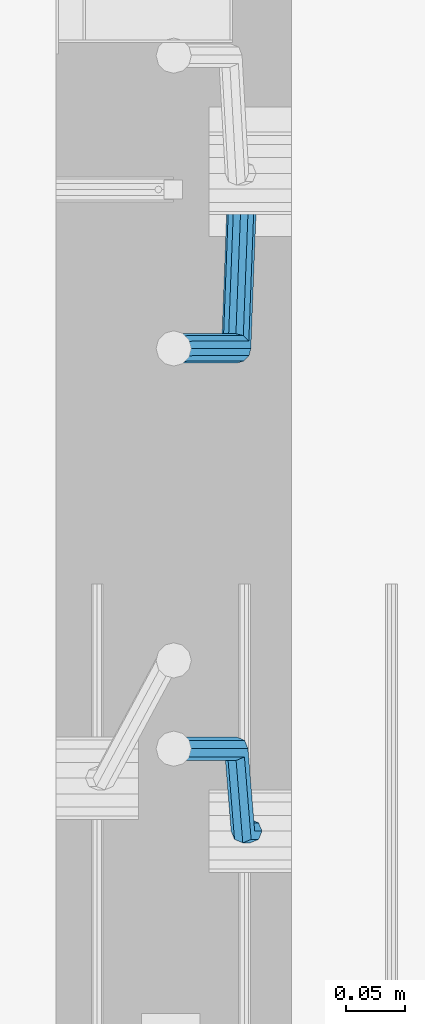
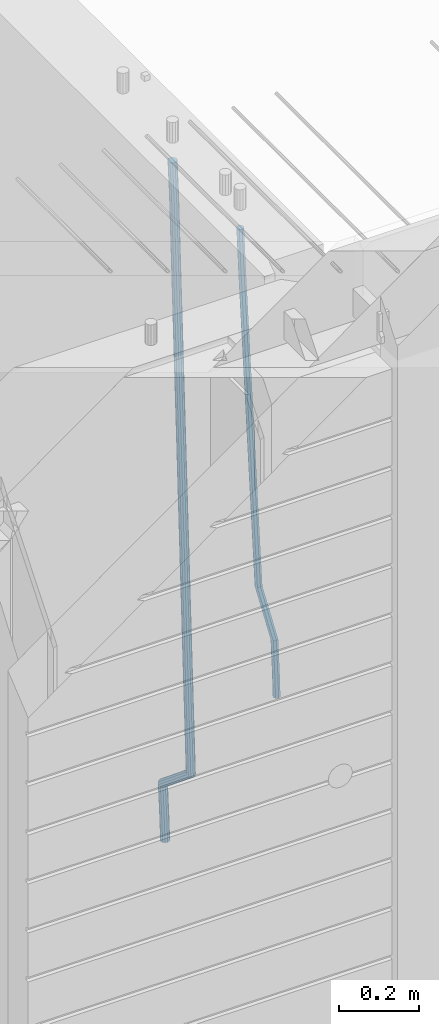
# One storey, part 109 of 350: 2 beams, 1 element without a shape of its own.
"""IFC2X3 building model written with IfcOpenShell, lengths in millimetres."""

from ifc_helpers import new_model, si_unit, frame, origin_with_axes, place, context, subcontext, project, spatial, faceted_brep, material, type_object, element, aggregate, save


model = new_model("IFC2X3")

# Units and contexts
model_context = context("Model", 3, precision=1e-05, world=origin_with_axes())
body_context = subcontext(model_context, "Body", "Model", "MODEL_VIEW")
ifc_project = project(units=[si_unit("LENGTHUNIT", "METRE", prefix="MILLI"), si_unit("AREAUNIT", "SQUARE_METRE"), si_unit("VOLUMEUNIT", "CUBIC_METRE"), si_unit("MASSUNIT", "GRAM", prefix="KILO"), si_unit("TIMEUNIT", "SECOND"), si_unit("PLANEANGLEUNIT", "RADIAN"), si_unit("SOLIDANGLEUNIT", "STERADIAN"), si_unit("THERMODYNAMICTEMPERATUREUNIT", "DEGREE_CELSIUS"), si_unit("LUMINOUSINTENSITYUNIT", "LUMEN")], contexts=[model_context])

# Site, building, storey
site_placement = place(None, origin_with_axes())
site = spatial("IfcSite", under=ifc_project, at=site_placement, CompositionType="ELEMENT")
building_placement = place(site_placement, origin_with_axes())
building = spatial("IfcBuilding", under=site, at=building_placement, CompositionType="ELEMENT")
storey_placement = place(building_placement, origin_with_axes())
storey = spatial("IfcBuildingStorey", under=building, at=storey_placement, Name="2", CompositionType="ELEMENT", Elevation=0.0)

# Assembly, beams
assembly_placement = place(storey_placement, origin_with_axes())
assembly = element("IfcElementAssembly", 1, at=assembly_placement, inside=storey, AssemblyPlace="NOTDEFINED", PredefinedType="REINFORCEMENT_UNIT")
ifc_material = material()
beam_type_1 = type_object("IfcBeamType", Name="D20", PredefinedType="NOTDEFINED")
beam_1_placement = place(assembly_placement, frame((28675.0000022791, 8255.00000000393, 85990.0), z_axis=(-0.999642804636942, -0.000205726999925762, -0.0267249099902983), x_axis=(-0.0267249099948371, 4.30000201934385e-08, 0.999642825806181)))
beam_1 = element("IfcBeam", 2, at=beam_1_placement, type_object=beam_type_1, material=ifc_material, Name="JM20", ObjectType="D20", context=body_context, shape_type="Brep", body=[
    faceted_brep([(0.0, -10.0, 0.0), (-4.19531716033816e-08, -7.07106781186667, -7.07106781187031), (60.4266690400545, -7.0710677960451, -7.07106780570757), (60.4266690441291, -9.99999998418934, 6.15546014159918e-09), (0.0, 0.0, -10.0), (60.426669036824, 1.58106558956206e-08, -9.99999999384454), (4.196772351861e-08, 7.07106781186303, -7.07106781186667), (60.4266690363438, 7.07106782768096, -7.07106780570757), (0.0, 10.0, 0.0), (60.4266690388904, 10.0000000158179, 6.15182216279209e-09), (4.196772351861e-08, 7.07106781185939, 7.07106781185939), (60.4266690429649, 7.07106782768096, 7.07106781802577), (0.0, 0.0, 10.0), (60.4266690461809, 1.58179318532348e-08, 10.0000000061555), (-4.19531716033816e-08, -7.07106781187031, 7.07106781185939), (60.4266690466611, -7.07106779605238, 7.07106781802213), (61.0378400410118, -7.07106779588503, -7.07106780564936), (60.991799419251, -9.99999998403655, 6.21366780251265e-09), (61.0569027789461, 1.5985278878361e-08, -9.99999999378269), (61.0378209396877, 7.07106782784831, -7.07106780564936), (60.9917724058905, 10.0000000159635, 6.21366780251265e-09), (60.9457317841297, 7.07106782781193, 7.0710678180767), (60.9266690461809, 1.59488990902901e-08, 10.0000000062028), (60.9457508854539, -7.07106779591413, 7.0710678180767), (61.6489592143771, -7.07106614513759, -7.06310863441468), (61.5568818710308, -9.9999984576425, 0.00735959856683621), (61.6870830769039, 1.71821739058942e-06, -9.99179257185824), (61.6489210170112, 7.07106947854481, -7.06310888312146), (61.556827851804, 10.0000015422847, 0.00735924683976918), (61.4647505084577, 7.07106922979438, 7.07782747982128), (61.4266266459163, 1.36643211590126e-06, 10.0065114172685), (61.464788705809, -7.07106639389531, 7.07782772852806), (173.929884088837, -7.07076285404219, -5.60077011527756), (173.837806745476, -9.99969516654164, 1.46969811770396), (173.968007951422, 0.000305009316434735, -8.52945405272476), (173.929845891558, 7.07137276964022, -5.6007703639807), (173.837752726366, 10.0003048333874, 1.46969776598417), (173.745675383005, 7.07137252088796, 8.54016599896204), (173.70755152042, 0.000304657529341057, 11.4688499364056), (173.745713580298, -7.07076310279444, 8.54016624766882), (178.967651291154, -7.07074924610424, -5.53515860522748), (179.629472357934, -9.99967952218321, 1.54512834527122), (177.143594814726, 0.000313587164782803, -8.48809544264077), (175.225810474018, 7.07137627027805, -5.58389181644088), (174.337710326101, 10.0003061838652, 1.47620917704262), (174.999531392881, 7.07137590778439, 8.5564961275486), (176.823587869323, 0.000313074517180212, 11.5094329649655), (178.741372210017, -7.07074960859609, 8.60522933875836), (183.345669120055, -4.57893716864601, -5.45009559540631), (184.66265755528, -7.13496947462954, 1.64292097623184), (179.903304691441, 1.57104232098936, -8.43447546265816), (176.352054665098, 7.71239441757098, -5.56200937456015), (174.772193143071, 10.2475983542226, 1.48465099193709), (176.089181578311, 7.69156604824093, 8.57766756357887), (179.531546006911, 1.54158655860192, 11.5620474308307), (183.082796033268, -4.59976553797787, 8.68958134273271), (300.866238429953, 62.309592161384, -3.16672130776351), (302.183226865163, 59.7535598554005, 3.92629526388191), (297.423874001339, 68.4595716510194, -6.15110117501899), (293.872623974981, 74.6009237475992, -3.27863508691371), (292.292762452984, 77.1361276842526, 3.7680252795908), (293.609750888194, 74.5800953782691, 10.8610418512253), (297.052115316808, 68.4301158886319, 13.8454217184808), (300.603365343151, 62.2887637920539, 10.9729556303828), (301.984297885341, 62.9459518481417, -3.14499789178808), (302.617709682163, 60.0008520257597, 3.93473707877274), (300.171977137725, 70.023694240961, -6.09770670902071), (298.242380353928, 77.0880337014878, -3.19373259352506), (297.325839159952, 80.0007759829532, 3.86581580262282), (297.959250956774, 77.0556761605694, 10.9455507731909), (299.771571704376, 69.9779337677501, 13.8982595904236), (301.701168488187, 62.9135943072251, 10.9942854749243), (303.270651347979, 62.9459576083173, -3.11711828318948), (303.117592289826, 60.0008542641881, 3.94557121718026), (303.333733847743, 70.0237083990232, -6.02918080060772), (303.269886916285, 77.0880562142083, -3.08476960685584), (303.116511220142, 80.0008019130601, 3.99131915397084), (302.963452161959, 77.0556985689309, 11.0540086543406), (302.900369662209, 69.9779477782249, 13.9660711717588), (302.964216593668, 62.9135999630416, 11.0216599780069), (1294.7217320068, 62.9503972368293, 18.3709632433638), (1294.56867294862, 60.005293892702, 25.4336527437299), (1294.78481450655, 70.0281480275353, 15.4589007259456), (1294.72096757509, 77.0924958427204, 18.4033119196974), (1294.56759187893, 80.0052415415721, 25.4794006805241), (1294.41453282078, 77.0601381974448, 32.5420901808939), (1294.35145032103, 69.9823874067388, 35.4541526983121), (1294.41529725248, 62.9180395915519, 32.5097415045602), (1295.22161461448, 62.9503994752577, 18.3817973817677), (1295.07888017438, 60.0052961773617, 25.4447106513508), (1295.31867057628, 70.028150418093, 15.4704711836021), (1295.31319399366, 77.0924984946578, 18.4161474592547), (1295.20839297447, 80.0052444110206, 25.4932889968004), (1295.06565853437, 77.0601411131283, 32.5562022663908), (1294.96860257258, 69.9823901702894, 35.4675284645564), (1294.97407915516, 62.9180420937282, 32.5218521889037), (1295.72152784184, 62.94388042639, 18.3884507330331), (1295.58911865226, 59.9986424835042, 25.4515014215031), (1295.85255934671, 70.0211883158863, 15.477576715788), (1295.90545668837, 77.0847751754136, 18.4240298907134), (1295.84923332153, 79.9968876216644, 25.5018179488325), (1295.71682413192, 77.0516496787768, 32.5648686373061), (1295.58579262707, 69.9743417892805, 35.4757426545511), (1295.53289528542, 62.9107549297532, 32.5292894796257), (1317.55234549895, 62.6591986870044, 18.6789973526284), (1317.41993630935, 59.7139607441186, 25.742048041102), (1317.68337700378, 69.7365065765007, 15.7681233353796), (1317.73627434546, 76.8000934360261, 18.7145765103051), (1317.68005097858, 79.7122058822752, 25.7923645684241), (1317.54764178899, 76.7669679393894, 32.8554152568977), (1317.41661028414, 69.6896600498949, 35.7662892741391), (1317.36371294248, 62.6260731903676, 32.8198360992174), (1318.18764454535, 62.6509141582064, 18.6874525554158), (1318.08001896468, 59.7053530281173, 25.7508330892488), (1318.26149780396, 69.7289676726632, 15.7758175521922), (1318.25831650323, 76.7932858179247, 18.7215243757819), (1318.17996420598, 79.7056868334112, 25.7990179196931), (1318.07233862529, 76.7601257033202, 32.8623984535188), (1317.9984853667, 69.6820721888635, 35.7740334567425), (1318.00166666745, 62.617754043602, 32.82832663316), (1318.82299738188, 62.6527874709518, 18.695714940186), (1318.74015733854, 59.7073214972279, 25.7594258266035), (1318.83966783619, 69.7306617061313, 15.783316930032), (1318.78040337538, 76.7948214685675, 18.7282750514532), (1318.67992031686, 79.7071777761994, 25.8054727775416), (1318.59708027351, 76.7617118024755, 32.8691836639591), (1318.58040981922, 69.683837567296, 35.7815816741204), (1318.63967428004, 62.6196778048579, 32.8366235526955), (1418.84378630333, 62.9510503382135, 19.9930854252816), (1418.76094625996, 60.0055843644896, 27.0567963116991), (1418.86045675761, 70.0289245733893, 17.080687415124), (1418.8011922968, 77.0930843358292, 20.0256455365488), (1418.70070923828, 80.0054406434592, 27.1028432626408), (1418.61786919495, 77.0599746697353, 34.1665541490511), (1418.60119874065, 69.9821004345595, 37.078952159216), (1418.66046320145, 62.9179406721196, 34.1339940377911)], [[[0, 1, 2, 3]], [[1, 4, 5, 2]], [[4, 6, 7, 5]], [[6, 8, 9, 7]], [[8, 10, 11, 9]], [[10, 12, 13, 11]], [[12, 14, 15, 13]], [[14, 0, 3, 15]], [[14, 12, 10, 8, 6, 4, 1, 0]], [[3, 2, 16, 17]], [[2, 5, 18, 16]], [[5, 7, 19, 18]], [[7, 9, 20, 19]], [[9, 11, 21, 20]], [[11, 13, 22, 21]], [[13, 15, 23, 22]], [[15, 3, 17, 23]], [[17, 16, 24, 25]], [[16, 18, 26, 24]], [[18, 19, 27, 26]], [[19, 20, 28, 27]], [[20, 21, 29, 28]], [[21, 22, 30, 29]], [[22, 23, 31, 30]], [[23, 17, 25, 31]], [[25, 24, 32, 33]], [[24, 26, 34, 32]], [[26, 27, 35, 34]], [[27, 28, 36, 35]], [[28, 29, 37, 36]], [[29, 30, 38, 37]], [[30, 31, 39, 38]], [[31, 25, 33, 39]], [[33, 32, 40, 41]], [[32, 34, 42, 40]], [[34, 35, 43, 42]], [[35, 36, 44, 43]], [[36, 37, 45, 44]], [[37, 38, 46, 45]], [[38, 39, 47, 46]], [[39, 33, 41, 47]], [[41, 40, 48, 49]], [[40, 42, 50, 48]], [[42, 43, 51, 50]], [[43, 44, 52, 51]], [[44, 45, 53, 52]], [[45, 46, 54, 53]], [[46, 47, 55, 54]], [[47, 41, 49, 55]], [[49, 48, 56, 57]], [[48, 50, 58, 56]], [[50, 51, 59, 58]], [[51, 52, 60, 59]], [[52, 53, 61, 60]], [[53, 54, 62, 61]], [[54, 55, 63, 62]], [[55, 49, 57, 63]], [[57, 56, 64, 65]], [[56, 58, 66, 64]], [[58, 59, 67, 66]], [[59, 60, 68, 67]], [[60, 61, 69, 68]], [[61, 62, 70, 69]], [[62, 63, 71, 70]], [[63, 57, 65, 71]], [[65, 64, 72, 73]], [[64, 66, 74, 72]], [[66, 67, 75, 74]], [[67, 68, 76, 75]], [[68, 69, 77, 76]], [[69, 70, 78, 77]], [[70, 71, 79, 78]], [[71, 65, 73, 79]], [[73, 72, 80, 81]], [[72, 74, 82, 80]], [[74, 75, 83, 82]], [[75, 76, 84, 83]], [[76, 77, 85, 84]], [[77, 78, 86, 85]], [[78, 79, 87, 86]], [[79, 73, 81, 87]], [[81, 80, 88, 89]], [[80, 82, 90, 88]], [[82, 83, 91, 90]], [[83, 84, 92, 91]], [[84, 85, 93, 92]], [[85, 86, 94, 93]], [[86, 87, 95, 94]], [[87, 81, 89, 95]], [[89, 88, 96, 97]], [[88, 90, 98, 96]], [[90, 91, 99, 98]], [[91, 92, 100, 99]], [[92, 93, 101, 100]], [[93, 94, 102, 101]], [[94, 95, 103, 102]], [[95, 89, 97, 103]], [[97, 96, 104, 105]], [[96, 98, 106, 104]], [[98, 99, 107, 106]], [[99, 100, 108, 107]], [[100, 101, 109, 108]], [[101, 102, 110, 109]], [[102, 103, 111, 110]], [[103, 97, 105, 111]], [[105, 104, 112, 113]], [[104, 106, 114, 112]], [[106, 107, 115, 114]], [[107, 108, 116, 115]], [[108, 109, 117, 116]], [[109, 110, 118, 117]], [[110, 111, 119, 118]], [[111, 105, 113, 119]], [[113, 112, 120, 121]], [[112, 114, 122, 120]], [[114, 115, 123, 122]], [[115, 116, 124, 123]], [[116, 117, 125, 124]], [[117, 118, 126, 125]], [[118, 119, 127, 126]], [[119, 113, 121, 127]], [[121, 120, 128, 129]], [[120, 122, 130, 128]], [[122, 123, 131, 130]], [[123, 124, 132, 131]], [[124, 125, 133, 132]], [[125, 126, 134, 133]], [[126, 127, 135, 134]], [[127, 121, 129, 135]], [[130, 131, 132, 133, 134, 135, 129, 128]]]),
])
beam_type_2 = type_object("IfcBeamType", Name="D25", PredefinedType="NOTDEFINED")
beam_2_placement = place(assembly_placement, frame((28675.0000022791, 8815.00000000393, 85210.0), z_axis=(-0.999642804636942, -0.000205726999925762, -0.0267249099902983), x_axis=(-0.0267249099948371, 4.30000201934385e-08, 0.999642825806181)))
beam_2 = element("IfcBeam", 3, at=beam_2_placement, type_object=beam_type_2, material=ifc_material, Name="JM25", ObjectType="D25", context=body_context, shape_type="Brep", body=[
    faceted_brep([(-7.41420080885291e-08, -12.5, -3.63797880709171e-12), (-6.42030499875546e-08, -10.8253175473074, -6.25000000000364), (60.4103898235917, -10.8253175318459, -6.2499999938409), (60.4103898269532, -12.4999999845422, 6.16273609921336e-09), (-3.70782800018787e-08, -6.25000000000364, -10.8253175473074), (60.4103898202884, -6.24999998454587, -10.8253175411446), (-1.45519152283669e-11, -3.63797880709171e-12, -12.5), (60.4103898179019, 1.54577719513327e-08, -12.4999999938373), (3.70637280866504e-08, 6.25, -10.8253175473074), (60.410389817087, 6.25000001545777, -10.825317541141), (6.42030499875546e-08, 10.8253175473001, -6.25000000000364), (60.410389818062, 10.8253175627578, -6.24999999383726), (7.41420080885291e-08, 12.4999999999927, 0.0), (60.4103898205503, 12.5000000154541, 6.16273609921336e-09), (6.42176019027829e-08, 10.8253175473001, 6.24999999999636), (60.4103898238973, 10.8253175627651, 6.2500000061591), (3.70928319171071e-08, 6.24999999999636, 10.8253175473037), (60.4103898272151, 6.25000001546141, 10.8253175534664), (1.45519152283669e-11, -3.63797880709171e-12, 12.4999999999964), (60.4103898296162, 1.54541339725256e-08, 12.5000000061591), (-3.7049176171422e-08, -6.25000000000364, 10.8253175473001), (60.4103898304165, -6.24999998454587, 10.8253175534701), (-6.41884980723262e-08, -10.8253175473074, 6.25), (60.4103898294561, -10.8253175318459, 6.25000000616637), (61.0324985728803, -10.8253175316895, -6.24999999377542), (60.991802792938, -12.4999999843931, 6.22458173893392e-09), (61.0622854283865, -6.24999998437852, -10.8253175410755), (61.0731819955545, 1.5628756955266e-08, -12.4999999937718), (61.0622685480339, 6.25000001562512, -10.8253175410791), (61.032469335245, 10.8253175629216, -6.24999999377178), (60.9917690322181, 12.5000000156033, 6.22458173893392e-09), (60.9510732522613, 10.8253175629034, 6.25000000621731), (60.9212863967696, 6.25000001558874, 10.8253175535247), (60.9103898296162, 1.55814632307738e-08, 12.5000000062137), (60.9213032771368, -6.24999998441126, 10.8253175535174), (60.9511024898966, -10.8253175317113, 6.25000000621731), (61.6545545670233, -10.8253158516927, -6.24189838219536), (61.573166454793, -12.499998414296, 0.00757164385504439), (61.7141257553885, -6.24999822394238, -10.8168280205282), (61.7359179680789, 1.80548886419274e-06, -12.491368569139), (61.7140919992817, 6.25000177601396, -10.8168282403167), (61.6544960997562, 10.8253192428383, -6.2418987628771), (61.5730989426083, 12.5000015856094, 0.0075712042817031), (61.4917108303925, 10.8253190230062, 6.25704123032847), (61.4321396420273, 6.25000139525582, 10.8319708686649), (61.4103474293224, 1.36582457344048e-06, 12.5065114172721), (61.4321733981196, -6.24999860470052, 10.8319710884571), (61.4917692976451, -10.8253160715249, 6.25704161101385), (170.650707434237, -10.8250214850323, -4.82234049238832), (170.569319321992, -12.4997040476355, 1.42712953365844), (170.710278622631, -6.24970385728193, -9.39727013072479), (170.732070835351, 0.000296172149319318, -11.071810679332), (170.710244866626, 6.2502961426726, -9.39727035051328), (170.650648967101, 10.8256136094988, -4.8223408730737), (170.569251809982, 12.5002959522735, 1.42712909408874), (170.487863697752, 10.8256133896703, 7.67659912013187), (170.428292509343, 6.2502957619181, 12.2515287584683), (170.406500296609, 0.000295732492304523, 13.9260693070792), (170.428326265363, -6.24970423803461, 12.2515289782568), (170.487922164859, -10.825021704859, 7.67659950081725), (171.95945989441, -10.8250179504703, -4.80529539646886), (171.069276921742, -12.4997026973942, 1.43364094472054), (174.195854831123, -6.24969444374983, -9.35187424218384), (177.179221514642, 0.00031358403248305, -10.9878434623934), (180.110169251391, 6.25032152914355, -9.2748464256947), (182.203352962257, 10.8256448100037, -4.67187930471846), (182.897905762278, 12.5003292483925, 1.58769657769517), (182.007722789611, 10.8256445014722, 7.82663291887729), (179.771327852883, 6.25032099474811, 12.3732117645959), (176.787961169364, 0.000312966967612738, 14.0091809848018), (173.857013432615, -6.24969497814527, 12.2961839481068), (171.763829721749, -10.8250182590036, 7.69321682713053), (172.789272050257, -11.8370779460765, -4.78886711087034), (171.386274143355, -12.8863205656235, 1.43991672756601), (176.405878190024, -8.94509510172611, -9.30812109317048), (181.267025868161, -4.98527650023061, -10.9069147643713), (186.070174490029, -1.01865233804529, -9.15685265142747), (189.528324261279, 1.89192364390146, -4.52686248419923), (190.714866743365, 2.96656496173455, 1.74245361104113), (189.311868836463, 1.91732234219126, 7.97123744947385), (185.695262696681, -0.974660502160987, 12.4904914317667), (180.834115018544, -4.93447910365467, 14.0892851029712), (176.030966396691, -8.90110326583999, 12.339222990031), (172.572816625441, -11.8116792477867, 7.70923282279909), (287.643682825365, -151.916436441259, -2.51502591843382), (286.240684918463, -152.965679060806, 3.71375791999526), (291.260288965132, -149.024453596909, -7.03427990073396), (296.121436643283, -145.064634995419, -8.63307357193844), (300.924585265137, -141.098010833231, -6.88301145899459), (304.382735036386, -138.187434851283, -2.25302129176634), (305.569277518473, -137.11279353345, 4.01629480347401), (304.166279611571, -138.162036152991, 10.2450786419104), (300.549673471804, -141.054018997345, 14.7643326242032), (295.688525793681, -145.013837598837, 16.3631262954077), (290.885377171784, -148.980461761024, 14.6130641824639), (287.427227400578, -151.891037742971, 9.98307401523562), (294.916872503818, -160.787003426849, -2.37103424950692), (294.057255182415, -162.498966818901, 3.86850721808514), (297.130944177028, -156.184453900582, -6.91805504216973), (300.10621148521, -149.924567668779, -8.55418461054069), (303.04545395587, -143.684676191968, -6.84102335805801), (305.16110394265, -139.136753352217, -2.23761145882963), (305.886274740114, -137.499411401677, 4.02257058631221), (305.026657418683, -139.211374793726, 10.2621120539116), (302.812585745487, -143.813924319997, 14.8091328465744), (299.83731843729, -150.073810551799, 16.445262414938), (296.89807596663, -156.313702028609, 14.732101162459), (294.782425979865, -160.861624868359, 10.1286892632306), (306.388880108789, -160.787002563869, -2.36635924463553), (306.386337397649, -162.498965891449, 3.87353149295086), (306.390733102453, -156.184453204016, -6.91428154760433), (306.391399870467, -149.924567195976, -8.55162330764142), (306.390701752913, -143.684675940322, -6.83966012240489), (306.388825809801, -139.13675325986, -2.23711114485923), (306.386274698583, -137.499411364064, 4.02277434335338), (306.383731987473, -139.21137469164, 10.2626650809325), (306.381878993809, -143.813924051496, 14.8105873839049), (306.38121222578, -150.073810059535, 16.4479291439384), (306.381910343349, -156.31370131519, 14.7359659587019), (306.38378628646, -160.86162399565, 10.1334169811526), (2074.25685482159, -160.78686957629, -1.64592811491093), (2074.25431211045, -162.49883290387, 4.59396262267182), (2074.25870781526, -156.184320216433, -6.19385041787609), (2074.25937458327, -149.924434208398, -7.83119217791682), (2074.25867646572, -143.684542952742, -6.11922899268029), (2074.25680052261, -139.136620272282, -1.51668001513099), (2074.25424941139, -137.499278376485, 4.7432054730707), (2074.25170670026, -139.211241704063, 10.9830962106571), (2074.24985370661, -143.813791063918, 15.5310185136332), (2074.24918693858, -150.073677071958, 17.1683602736666), (2074.24988505615, -156.313568327612, 15.4563970884265), (2074.25176099925, -160.861491008072, 10.8538481108772), (2074.83800415983, -160.786869532572, -1.64569128836229), (2074.78405199363, -162.498832864021, 4.59417849914462), (2074.89919820712, -156.184320168253, -6.19358940901657), (2074.95123723999, -149.924434156354, -7.83091023412271), (2074.98017744161, -143.684542898467, -6.11893497085839), (2074.9782643083, -139.136620218011, -1.51638600846127), (2074.94601046259, -137.499278324447, 4.74348737546097), (2074.89205829642, -139.211241655892, 10.9833571629642), (2074.83086424912, -143.813791020213, 15.5312552836185), (2074.77882521624, -150.073677032115, 17.1685761087319), (2074.74988501464, -156.313568289999, 15.4566008454603), (2074.75179814795, -160.861490970456, 10.8540518830705), (2075.41905269311, -160.794446422529, -1.63795810662486), (2075.31369998924, -162.505739489452, 4.60122759051956), (2075.53957750089, -156.192670733069, -6.18506659349441), (2075.64297988769, -149.933454500813, -7.82170382312688), (2075.70155326747, -143.693949660443, -6.10933417154229), (2075.69960295041, -139.146026495109, -1.50678570403034), (2075.6376515224, -137.508297344199, 4.75269243442381), (2075.53229881854, -139.219590411121, 10.9918781315719), (2075.41177401076, -143.821366100581, 15.5389866184414), (2075.30837162396, -150.080582332837, 17.1756238480739), (2075.24979824419, -156.320087173208, 15.4632541964893), (2075.25174856123, -160.868010338543, 10.8607057289737), (2097.19475506655, -161.07840222163, -1.34814502872177), (2097.0894023627, -162.789695288553, 4.89104066842629), (2097.31527987434, -156.47662653217, -5.89525351558768), (2097.41868226114, -150.217410299914, -7.53189074522379), (2097.47725564092, -143.977905459546, -5.8195210936392), (2097.47530532385, -139.42998229421, -1.21697262612361), (2097.41335389586, -137.7922531433, 5.0425055123269), (2097.308001192, -139.503546210224, 11.2816912094786), (2097.18747638421, -144.105321899684, 15.8287996963445), (2097.08407399742, -150.36453813194, 17.465436925977), (2097.02550061764, -156.604042972309, 15.7530672743924), (2097.02745093469, -161.151966137644, 11.1505188068804), (2097.88009758113, -161.08733910817, -1.33902379716892), (2097.78950535266, -162.798824652125, 4.90035834732043), (2097.96299662867, -156.48507277769, -5.88663304572037), (2098.01598976244, -150.225199207291, -7.52394117269068), (2098.02487751505, -143.985046464883, -5.81223278769903), (2097.98727842035, -139.436658438441, -1.21015877018363), (2097.9132671254, -137.79877202651, 5.04915886335584), (2097.82267489695, -139.510257570466, 11.2885410078416), (2097.73977584939, -144.112523900945, 15.8361502563967), (2097.68678271561, -150.372397471347, 17.4734583833706), (2097.67789496301, -156.612550213753, 15.7617499983789), (2097.7154940577, -161.160938240195, 11.1596759808635), (2098.56549792843, -161.085317088931, -1.33009606953055), (2098.4896672887, -162.796737016384, 4.9094834726202), (2098.61076827119, -156.483178710125, -5.87820933279363), (2098.61334816522, -150.223461142012, -7.51619304119231), (2098.57254632999, -143.98345065182, -5.80515078284952), (2098.49929558429, -139.435153011162, -1.20355494909745), (2098.4132234063, -137.797280899784, 5.05560057250841), (2098.33739276657, -139.508700827235, 11.2951801146628), (2098.29212242381, -144.110839206043, 15.8432933779259), (2098.28954252979, -150.370556774154, 17.4812770863246), (2098.33034436501, -156.610567264344, 15.7702348279781), (2098.40359511071, -161.158864905006, 11.1686389942297), (2198.56627518767, -160.787113942532, -0.0329775665668421), (2198.49044454792, -162.498533869981, 6.20660197558027), (2198.61154553041, -156.184975563721, -4.58109082982992), (2198.61412542444, -149.92525799561, -6.21907453823587), (2198.57332358921, -143.68524750542, -4.50803227988581), (2198.50007284353, -139.136949864758, 0.0935635538662609), (2198.41400066552, -137.499077753379, 6.35271907547576), (2198.33817002579, -139.210497680831, 12.5922986176229), (2198.29289968305, -143.81263605964, 17.1404118808859), (2198.29031978901, -150.072353627755, 18.7783955892846), (2198.33112162424, -156.312364117945, 17.0673533309418), (2198.40437236994, -160.860661758603, 12.4657574971934)], [[[0, 1, 2, 3]], [[1, 4, 5, 2]], [[4, 6, 7, 5]], [[6, 8, 9, 7]], [[8, 10, 11, 9]], [[10, 12, 13, 11]], [[12, 14, 15, 13]], [[14, 16, 17, 15]], [[16, 18, 19, 17]], [[18, 20, 21, 19]], [[20, 22, 23, 21]], [[22, 0, 3, 23]], [[22, 20, 18, 16, 14, 12, 10, 8, 6, 4, 1, 0]], [[3, 2, 24, 25]], [[2, 5, 26, 24]], [[5, 7, 27, 26]], [[7, 9, 28, 27]], [[9, 11, 29, 28]], [[11, 13, 30, 29]], [[13, 15, 31, 30]], [[15, 17, 32, 31]], [[17, 19, 33, 32]], [[19, 21, 34, 33]], [[21, 23, 35, 34]], [[23, 3, 25, 35]], [[25, 24, 36, 37]], [[24, 26, 38, 36]], [[26, 27, 39, 38]], [[27, 28, 40, 39]], [[28, 29, 41, 40]], [[29, 30, 42, 41]], [[30, 31, 43, 42]], [[31, 32, 44, 43]], [[32, 33, 45, 44]], [[33, 34, 46, 45]], [[34, 35, 47, 46]], [[35, 25, 37, 47]], [[37, 36, 48, 49]], [[36, 38, 50, 48]], [[38, 39, 51, 50]], [[39, 40, 52, 51]], [[40, 41, 53, 52]], [[41, 42, 54, 53]], [[42, 43, 55, 54]], [[43, 44, 56, 55]], [[44, 45, 57, 56]], [[45, 46, 58, 57]], [[46, 47, 59, 58]], [[47, 37, 49, 59]], [[49, 48, 60, 61]], [[48, 50, 62, 60]], [[50, 51, 63, 62]], [[51, 52, 64, 63]], [[52, 53, 65, 64]], [[53, 54, 66, 65]], [[54, 55, 67, 66]], [[55, 56, 68, 67]], [[56, 57, 69, 68]], [[57, 58, 70, 69]], [[58, 59, 71, 70]], [[59, 49, 61, 71]], [[61, 60, 72, 73]], [[60, 62, 74, 72]], [[62, 63, 75, 74]], [[63, 64, 76, 75]], [[64, 65, 77, 76]], [[65, 66, 78, 77]], [[66, 67, 79, 78]], [[67, 68, 80, 79]], [[68, 69, 81, 80]], [[69, 70, 82, 81]], [[70, 71, 83, 82]], [[71, 61, 73, 83]], [[73, 72, 84, 85]], [[72, 74, 86, 84]], [[74, 75, 87, 86]], [[75, 76, 88, 87]], [[76, 77, 89, 88]], [[77, 78, 90, 89]], [[78, 79, 91, 90]], [[79, 80, 92, 91]], [[80, 81, 93, 92]], [[81, 82, 94, 93]], [[82, 83, 95, 94]], [[83, 73, 85, 95]], [[85, 84, 96, 97]], [[84, 86, 98, 96]], [[86, 87, 99, 98]], [[87, 88, 100, 99]], [[88, 89, 101, 100]], [[89, 90, 102, 101]], [[90, 91, 103, 102]], [[91, 92, 104, 103]], [[92, 93, 105, 104]], [[93, 94, 106, 105]], [[94, 95, 107, 106]], [[95, 85, 97, 107]], [[97, 96, 108, 109]], [[96, 98, 110, 108]], [[98, 99, 111, 110]], [[99, 100, 112, 111]], [[100, 101, 113, 112]], [[101, 102, 114, 113]], [[102, 103, 115, 114]], [[103, 104, 116, 115]], [[104, 105, 117, 116]], [[105, 106, 118, 117]], [[106, 107, 119, 118]], [[107, 97, 109, 119]], [[109, 108, 120, 121]], [[108, 110, 122, 120]], [[110, 111, 123, 122]], [[111, 112, 124, 123]], [[112, 113, 125, 124]], [[113, 114, 126, 125]], [[114, 115, 127, 126]], [[115, 116, 128, 127]], [[116, 117, 129, 128]], [[117, 118, 130, 129]], [[118, 119, 131, 130]], [[119, 109, 121, 131]], [[121, 120, 132, 133]], [[120, 122, 134, 132]], [[122, 123, 135, 134]], [[123, 124, 136, 135]], [[124, 125, 137, 136]], [[125, 126, 138, 137]], [[126, 127, 139, 138]], [[127, 128, 140, 139]], [[128, 129, 141, 140]], [[129, 130, 142, 141]], [[130, 131, 143, 142]], [[131, 121, 133, 143]], [[133, 132, 144, 145]], [[132, 134, 146, 144]], [[134, 135, 147, 146]], [[135, 136, 148, 147]], [[136, 137, 149, 148]], [[137, 138, 150, 149]], [[138, 139, 151, 150]], [[139, 140, 152, 151]], [[140, 141, 153, 152]], [[141, 142, 154, 153]], [[142, 143, 155, 154]], [[143, 133, 145, 155]], [[145, 144, 156, 157]], [[144, 146, 158, 156]], [[146, 147, 159, 158]], [[147, 148, 160, 159]], [[148, 149, 161, 160]], [[149, 150, 162, 161]], [[150, 151, 163, 162]], [[151, 152, 164, 163]], [[152, 153, 165, 164]], [[153, 154, 166, 165]], [[154, 155, 167, 166]], [[155, 145, 157, 167]], [[157, 156, 168, 169]], [[156, 158, 170, 168]], [[158, 159, 171, 170]], [[159, 160, 172, 171]], [[160, 161, 173, 172]], [[161, 162, 174, 173]], [[162, 163, 175, 174]], [[163, 164, 176, 175]], [[164, 165, 177, 176]], [[165, 166, 178, 177]], [[166, 167, 179, 178]], [[167, 157, 169, 179]], [[169, 168, 180, 181]], [[168, 170, 182, 180]], [[170, 171, 183, 182]], [[171, 172, 184, 183]], [[172, 173, 185, 184]], [[173, 174, 186, 185]], [[174, 175, 187, 186]], [[175, 176, 188, 187]], [[176, 177, 189, 188]], [[177, 178, 190, 189]], [[178, 179, 191, 190]], [[179, 169, 181, 191]], [[181, 180, 192, 193]], [[180, 182, 194, 192]], [[182, 183, 195, 194]], [[183, 184, 196, 195]], [[184, 185, 197, 196]], [[185, 186, 198, 197]], [[186, 187, 199, 198]], [[187, 188, 200, 199]], [[188, 189, 201, 200]], [[189, 190, 202, 201]], [[190, 191, 203, 202]], [[191, 181, 193, 203]], [[194, 195, 196, 197, 198, 199, 200, 201, 202, 203, 193, 192]]]),
])
aggregate(assembly, [beam_1, beam_2])

save(model, "model.ifc")
